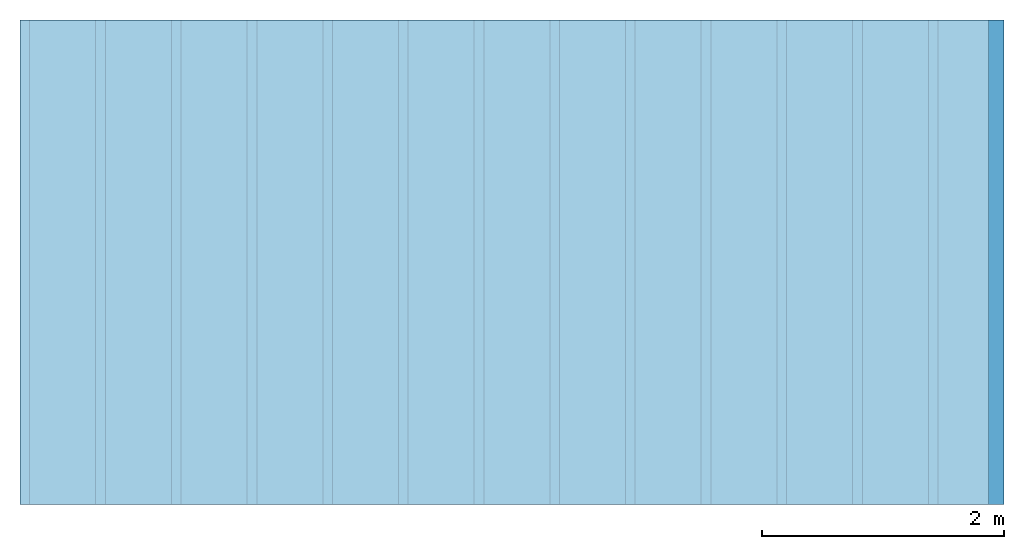
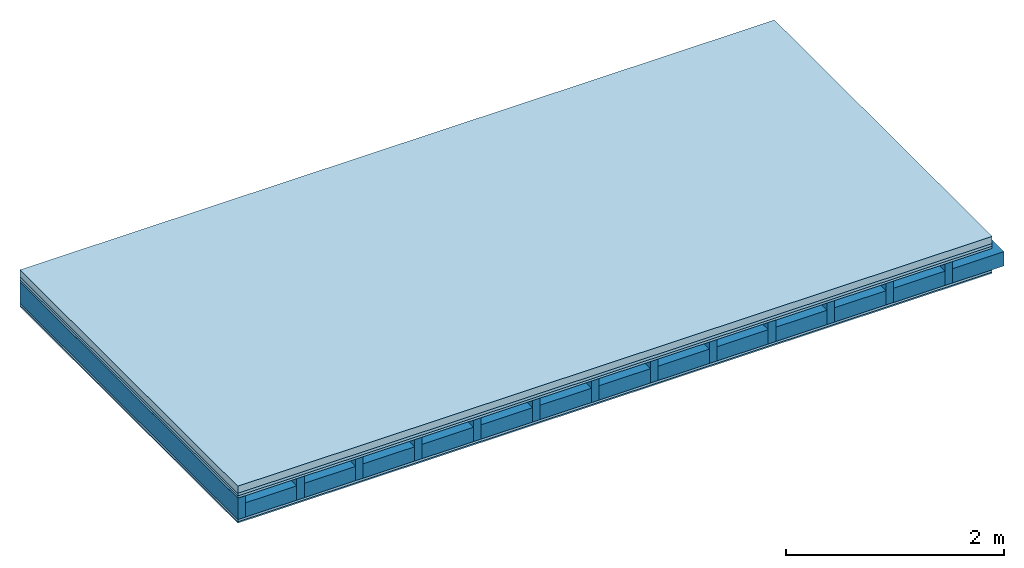
# One storey: 5 plates, 2 members, 1 element without a shape of its own.
"""IFC4 building model written with IfcOpenShell, lengths in metres."""

from ifc_helpers import new_model, si_unit, derived_unit, direction, frame, frame_2d, origin, origin_with_axes, place, context, project, spatial, rectangle, extrude, material, layer, layer_set, type_object, element, aggregate, save


model = new_model("IFC4")

# Units and contexts
plan_context = context("Plan", 3, precision=1e-05, world=origin(), true_north=direction((0.0, 1.0)))
model_context = context("Model", 3, precision=1e-05, world=origin(), true_north=direction((0.0, 1.0)))
ifc_project = project(units=[si_unit("LENGTHUNIT", "METRE"), derived_unit("SOUNDPRESSUREUNIT", [(si_unit("PRESSUREUNIT", "PASCAL", prefix="MICRO"), 0)]), si_unit("ENERGYUNIT", "JOULE", prefix="MEGA"), si_unit("MASSUNIT", "GRAM", prefix="KILO"), derived_unit("THERMALTRANSMITTANCEUNIT", [(si_unit("POWERUNIT", "WATT"), 1), (si_unit("AREAUNIT", "SQUARE_METRE"), -1), (si_unit("THERMODYNAMICTEMPERATUREUNIT", "KELVIN"), -1)]), derived_unit("AREADENSITYUNIT", [(si_unit("MASSUNIT", "GRAM", prefix="KILO"), 1), (si_unit("AREAUNIT", "SQUARE_METRE"), -1)]), derived_unit("USERDEFINED", [(si_unit("ENERGYUNIT", "JOULE", prefix="MEGA"), 1), (si_unit("AREAUNIT", "SQUARE_METRE"), -1)])], contexts=[plan_context, model_context])

# Site, building, storey
site = spatial("IfcSite", under=ifc_project)
building_placement = place(None, origin())
building = spatial("IfcBuilding", under=site, at=building_placement)
storey_placement = place(building_placement, origin())
storey = spatial("IfcBuildingStorey", under=building, at=storey_placement)

# Slab, members, plates
ifc_material_1 = material(Name="Cement screed", Category="04.006")
ifc_layer_1 = layer(ifc_material_1, 0.08, Name="On-material")
ifc_material_2 = material()
ifc_layer_2 = layer(ifc_material_2, 0.03, Name="Impact sound insulation")
ifc_material_3 = material(Category="07.001")
ifc_layer_3 = layer(ifc_material_3, 0.025, Name="Sub-floor")
ifc_material_4 = material(Name="Rigid, of the art")
ifc_layer_4 = layer(ifc_material_4, 0.0, Name="Bond")
ifc_layer_5 = layer(None, 0.24, Name="Supporting structure")
ifc_layer_6 = layer(ifc_material_4, 0.0, Name="Bond")
ifc_layer_7 = layer(ifc_material_3, 0.025, Name="Lower layer 1")
ifc_material_5 = material(Category="03.007")
ifc_layer_8 = layer(ifc_material_5, 0.015, Name="Lower 2nd layer")
ifc_layer_set = layer_set([ifc_layer_1, ifc_layer_2, ifc_layer_3, ifc_layer_4, ifc_layer_5, ifc_layer_6, ifc_layer_7, ifc_layer_8])
slab_type = type_object("IfcSlabType", Name="A0456", PredefinedType="NOTDEFINED", material=ifc_layer_set)
slab_placement = place(None, frame((0.0, 0.0, 0.0), z_axis=(0.0, 0.0, -1.0), x_axis=(1.0, 0.0, 0.0)))
slab = element("IfcSlab", 1, at=slab_placement, inside=storey, type_object=slab_type, material=ifc_layer_set, Name="Slab #1")
ifc_material_6 = material()
member_1_placement = place(slab_placement, origin())
member_1 = element("IfcMember", 2, at=member_1_placement, material=ifc_material_6, Name="Supporting structure", context=plan_context, shape_type="SweptSolid", body=[
    extrude(rectangle(XDim=0.08, YDim=0.24, at=frame_2d((0.04, 0.12), x_axis=(1.0, 0.0))), frame((0.0, 4.0, 0.135), z_axis=(0.0, -1.0, 0.0), x_axis=(1.0, 0.0, 0.0)), (0.0, 0.0, 1.0), 4.0),
    extrude(rectangle(XDim=0.08, YDim=0.24, at=frame_2d((0.04, 0.12), x_axis=(1.0, 0.0))), frame((0.625, 4.0, 0.135), z_axis=(0.0, -1.0, 0.0), x_axis=(1.0, 0.0, 0.0)), (0.0, 0.0, 1.0), 4.0),
    extrude(rectangle(XDim=0.08, YDim=0.24, at=frame_2d((0.04, 0.12), x_axis=(1.0, 0.0))), frame((1.25, 4.0, 0.135), z_axis=(0.0, -1.0, 0.0), x_axis=(1.0, 0.0, 0.0)), (0.0, 0.0, 1.0), 4.0),
    extrude(rectangle(XDim=0.08, YDim=0.24, at=frame_2d((0.04, 0.12), x_axis=(1.0, 0.0))), frame((1.875, 4.0, 0.135), z_axis=(0.0, -1.0, 0.0), x_axis=(1.0, 0.0, 0.0)), (0.0, 0.0, 1.0), 4.0),
    extrude(rectangle(XDim=0.08, YDim=0.24, at=frame_2d((0.04, 0.12), x_axis=(1.0, 0.0))), frame((2.5, 4.0, 0.135), z_axis=(0.0, -1.0, 0.0), x_axis=(1.0, 0.0, 0.0)), (0.0, 0.0, 1.0), 4.0),
    extrude(rectangle(XDim=0.08, YDim=0.24, at=frame_2d((0.04, 0.12), x_axis=(1.0, 0.0))), frame((3.125, 4.0, 0.135), z_axis=(0.0, -1.0, 0.0), x_axis=(1.0, 0.0, 0.0)), (0.0, 0.0, 1.0), 4.0),
    extrude(rectangle(XDim=0.08, YDim=0.24, at=frame_2d((0.04, 0.12), x_axis=(1.0, 0.0))), frame((3.75, 4.0, 0.135), z_axis=(0.0, -1.0, 0.0), x_axis=(1.0, 0.0, 0.0)), (0.0, 0.0, 1.0), 4.0),
    extrude(rectangle(XDim=0.08, YDim=0.24, at=frame_2d((0.04, 0.12), x_axis=(1.0, 0.0))), frame((4.375, 4.0, 0.135), z_axis=(0.0, -1.0, 0.0), x_axis=(1.0, 0.0, 0.0)), (0.0, 0.0, 1.0), 4.0),
    extrude(rectangle(XDim=0.08, YDim=0.24, at=frame_2d((0.04, 0.12), x_axis=(1.0, 0.0))), frame((5.0, 4.0, 0.135), z_axis=(0.0, -1.0, 0.0), x_axis=(1.0, 0.0, 0.0)), (0.0, 0.0, 1.0), 4.0),
    extrude(rectangle(XDim=0.08, YDim=0.24, at=frame_2d((0.04, 0.12), x_axis=(1.0, 0.0))), frame((5.625, 4.0, 0.135), z_axis=(0.0, -1.0, 0.0), x_axis=(1.0, 0.0, 0.0)), (0.0, 0.0, 1.0), 4.0),
    extrude(rectangle(XDim=0.08, YDim=0.24, at=frame_2d((0.04, 0.12), x_axis=(1.0, 0.0))), frame((6.25, 4.0, 0.135), z_axis=(0.0, -1.0, 0.0), x_axis=(1.0, 0.0, 0.0)), (0.0, 0.0, 1.0), 4.0),
    extrude(rectangle(XDim=0.08, YDim=0.24, at=frame_2d((0.04, 0.12), x_axis=(1.0, 0.0))), frame((6.875, 4.0, 0.135), z_axis=(0.0, -1.0, 0.0), x_axis=(1.0, 0.0, 0.0)), (0.0, 0.0, 1.0), 4.0),
    extrude(rectangle(XDim=0.08, YDim=0.24, at=frame_2d((0.04, 0.12), x_axis=(1.0, 0.0))), frame((7.5, 4.0, 0.135), z_axis=(0.0, -1.0, 0.0), x_axis=(1.0, 0.0, 0.0)), (0.0, 0.0, 1.0), 4.0),
])
ifc_material_7 = material()
member_2_placement = place(slab_placement, origin())
member_2 = element("IfcMember", 3, at=member_2_placement, material=ifc_material_7, Name="in supporting structure", context=plan_context, shape_type="SweptSolid", body=[
    extrude(rectangle(XDim=0.545, YDim=0.16, at=frame_2d((0.2725, 0.08), x_axis=(1.0, 0.0))), frame((0.08, 4.0, 0.215), z_axis=(0.0, -1.0, 0.0), x_axis=(1.0, 0.0, 0.0)), (0.0, 0.0, 1.0), 4.0),
    extrude(rectangle(XDim=0.545, YDim=0.16, at=frame_2d((0.2725, 0.08), x_axis=(1.0, 0.0))), frame((0.705, 4.0, 0.215), z_axis=(0.0, -1.0, 0.0), x_axis=(1.0, 0.0, 0.0)), (0.0, 0.0, 1.0), 4.0),
    extrude(rectangle(XDim=0.545, YDim=0.16, at=frame_2d((0.2725, 0.08), x_axis=(1.0, 0.0))), frame((1.33, 4.0, 0.215), z_axis=(0.0, -1.0, 0.0), x_axis=(1.0, 0.0, 0.0)), (0.0, 0.0, 1.0), 4.0),
    extrude(rectangle(XDim=0.545, YDim=0.16, at=frame_2d((0.2725, 0.08), x_axis=(1.0, 0.0))), frame((1.955, 4.0, 0.215), z_axis=(0.0, -1.0, 0.0), x_axis=(1.0, 0.0, 0.0)), (0.0, 0.0, 1.0), 4.0),
    extrude(rectangle(XDim=0.545, YDim=0.16, at=frame_2d((0.2725, 0.08), x_axis=(1.0, 0.0))), frame((2.58, 4.0, 0.215), z_axis=(0.0, -1.0, 0.0), x_axis=(1.0, 0.0, 0.0)), (0.0, 0.0, 1.0), 4.0),
    extrude(rectangle(XDim=0.545, YDim=0.16, at=frame_2d((0.2725, 0.08), x_axis=(1.0, 0.0))), frame((3.205, 4.0, 0.215), z_axis=(0.0, -1.0, 0.0), x_axis=(1.0, 0.0, 0.0)), (0.0, 0.0, 1.0), 4.0),
    extrude(rectangle(XDim=0.545, YDim=0.16, at=frame_2d((0.2725, 0.08), x_axis=(1.0, 0.0))), frame((3.83, 4.0, 0.215), z_axis=(0.0, -1.0, 0.0), x_axis=(1.0, 0.0, 0.0)), (0.0, 0.0, 1.0), 4.0),
    extrude(rectangle(XDim=0.545, YDim=0.16, at=frame_2d((0.2725, 0.08), x_axis=(1.0, 0.0))), frame((4.455, 4.0, 0.215), z_axis=(0.0, -1.0, 0.0), x_axis=(1.0, 0.0, 0.0)), (0.0, 0.0, 1.0), 4.0),
    extrude(rectangle(XDim=0.545, YDim=0.16, at=frame_2d((0.2725, 0.08), x_axis=(1.0, 0.0))), frame((5.08, 4.0, 0.215), z_axis=(0.0, -1.0, 0.0), x_axis=(1.0, 0.0, 0.0)), (0.0, 0.0, 1.0), 4.0),
    extrude(rectangle(XDim=0.545, YDim=0.16, at=frame_2d((0.2725, 0.08), x_axis=(1.0, 0.0))), frame((5.705, 4.0, 0.215), z_axis=(0.0, -1.0, 0.0), x_axis=(1.0, 0.0, 0.0)), (0.0, 0.0, 1.0), 4.0),
    extrude(rectangle(XDim=0.545, YDim=0.16, at=frame_2d((0.2725, 0.08), x_axis=(1.0, 0.0))), frame((6.33, 4.0, 0.215), z_axis=(0.0, -1.0, 0.0), x_axis=(1.0, 0.0, 0.0)), (0.0, 0.0, 1.0), 4.0),
    extrude(rectangle(XDim=0.545, YDim=0.16, at=frame_2d((0.2725, 0.08), x_axis=(1.0, 0.0))), frame((6.955, 4.0, 0.215), z_axis=(0.0, -1.0, 0.0), x_axis=(1.0, 0.0, 0.0)), (0.0, 0.0, 1.0), 4.0),
    extrude(rectangle(XDim=0.545, YDim=0.16, at=frame_2d((0.2725, 0.08), x_axis=(1.0, 0.0))), frame((7.58, 4.0, 0.215), z_axis=(0.0, -1.0, 0.0), x_axis=(1.0, 0.0, 0.0)), (0.0, 0.0, 1.0), 4.0),
])
plate_1_placement = place(slab_placement, origin())
plate_1 = element("IfcPlate", 4, at=plate_1_placement, material=ifc_material_1, Name="On-material", context=plan_context, shape_type="SweptSolid", body=[
    extrude(rectangle(XDim=8.0, YDim=4.0, at=frame_2d((4.0, 2.0), x_axis=(1.0, 0.0))), origin_with_axes(), (0.0, 0.0, 1.0), 0.08),
])
plate_2_placement = place(slab_placement, origin())
plate_2 = element("IfcPlate", 5, at=plate_2_placement, material=ifc_material_2, Name="Impact sound insulation", context=plan_context, shape_type="SweptSolid", body=[
    extrude(rectangle(XDim=8.0, YDim=4.0, at=frame_2d((4.0, 2.0), x_axis=(1.0, 0.0))), frame((0.0, 0.0, 0.08), z_axis=(0.0, 0.0, 1.0), x_axis=(1.0, 0.0, 0.0)), (0.0, 0.0, 1.0), 0.03),
])
plate_3_placement = place(slab_placement, origin())
plate_3 = element("IfcPlate", 6, at=plate_3_placement, material=ifc_material_3, Name="Sub-floor", context=plan_context, shape_type="SweptSolid", body=[
    extrude(rectangle(XDim=8.0, YDim=4.0, at=frame_2d((4.0, 2.0), x_axis=(1.0, 0.0))), frame((0.0, 0.0, 0.11), z_axis=(0.0, 0.0, 1.0), x_axis=(1.0, 0.0, 0.0)), (0.0, 0.0, 1.0), 0.025),
])
plate_4_placement = place(slab_placement, origin())
plate_4 = element("IfcPlate", 7, at=plate_4_placement, material=ifc_material_3, Name="Lower layer 1", context=plan_context, shape_type="SweptSolid", body=[
    extrude(rectangle(XDim=8.0, YDim=4.0, at=frame_2d((4.0, 2.0), x_axis=(1.0, 0.0))), frame((0.0, 0.0, 0.375), z_axis=(0.0, 0.0, 1.0), x_axis=(1.0, 0.0, 0.0)), (0.0, 0.0, 1.0), 0.025),
])
plate_5_placement = place(slab_placement, origin())
plate_5 = element("IfcPlate", 8, at=plate_5_placement, material=ifc_material_5, Name="Lower 2nd layer", context=plan_context, shape_type="SweptSolid", body=[
    extrude(rectangle(XDim=8.0, YDim=4.0, at=frame_2d((4.0, 2.0), x_axis=(1.0, 0.0))), frame((0.0, 0.0, 0.4), z_axis=(0.0, 0.0, 1.0), x_axis=(1.0, 0.0, 0.0)), (0.0, 0.0, 1.0), 0.015),
])
aggregate(slab, [plate_1, plate_2, plate_3, member_1, member_2, plate_4, plate_5])

save(model, "model.ifc")
